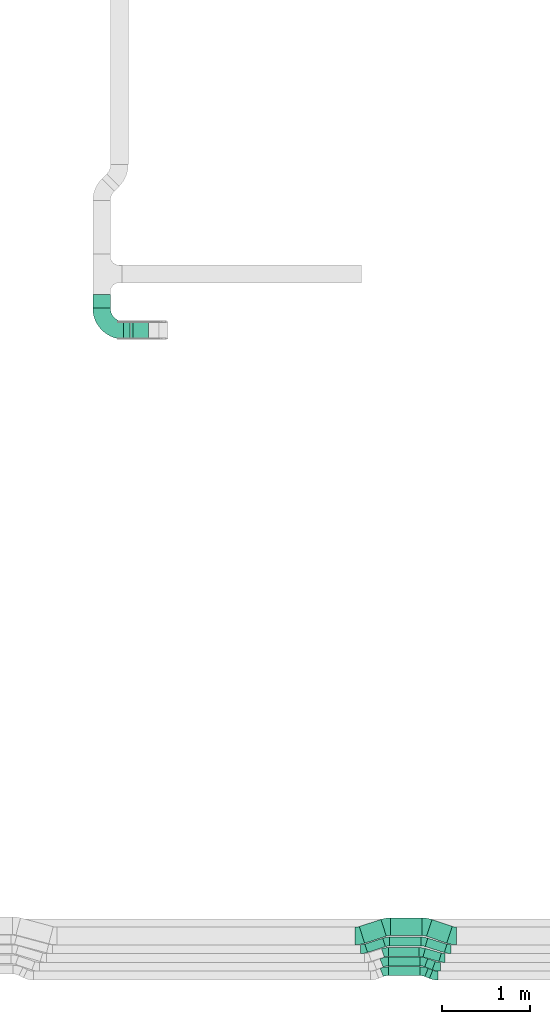
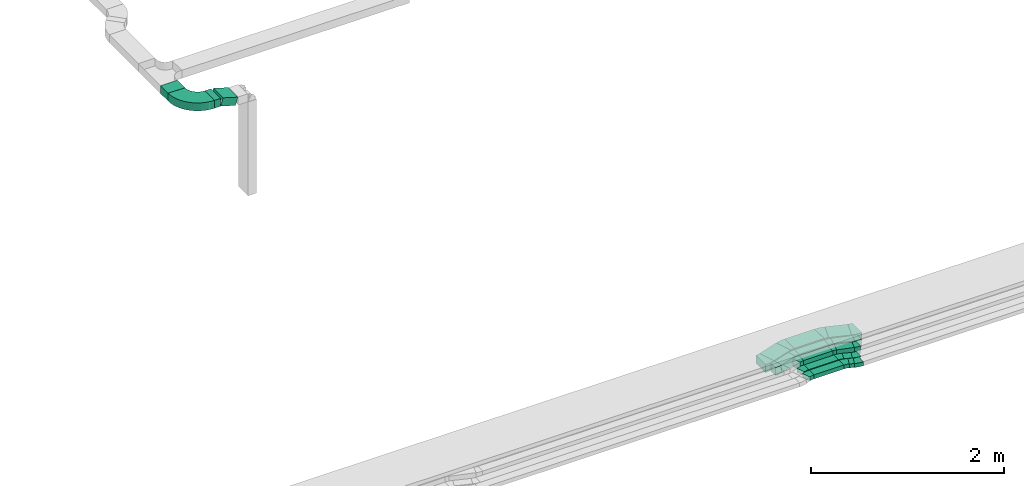
# One storey, part 20 of 38: 18 flow fittings, 15 flow segments.
"""IFC2X3 building model written with IfcOpenShell, lengths in millimetres."""

import ifcopenshell
import ifcopenshell.guid

model = None  # the IFC model being written
_history = None  # IfcOwnerHistory: only IFC2X3 demands one
_inside = {}  # id of a spatial element -> (the spatial element, [elements in it])
_under = {}  # id of a project, library or spatial element -> (it, [spatial elements below it])
_declared = {}  # id of a project -> (the project, [libraries it declares])
_typed = {}  # id of a type object -> (the type object, [elements of that type])
_made_of = {}  # id of a material, layer set ... -> (it, [elements and type objects made of it])


def new_model(schema):
    """Start an empty IFC model of exactly this schema.

    Asked for "IFC4X3", IfcOpenShell would pick the latest addendum, in which some entities
    have other attributes; the version numbers below select the first issue.
    IFC2X3 requires an IfcOwnerHistory on every rooted entity: one is made here for all.
    """
    global model, _history
    if schema == "IFC4X3":
        model = ifcopenshell.file(schema_version=(4, 3, 0, 0))
    else:
        model = ifcopenshell.file(schema=schema)
    _inside.clear()
    _under.clear()
    _declared.clear()
    _typed.clear()
    _made_of.clear()
    _history = None
    if model.schema == "IFC2X3":
        org = make("IfcOrganization", Name="unknown")
        user = make(
            "IfcPersonAndOrganization",
            ThePerson=make("IfcPerson", FamilyName="unknown"),
            TheOrganization=org,
        )
        app = make(
            "IfcApplication",
            ApplicationDeveloper=org,
            Version="unknown",
            ApplicationFullName="unknown",
            ApplicationIdentifier="unknown",
        )
        _history = make(
            "IfcOwnerHistory",
            OwningUser=user,
            OwningApplication=app,
            ChangeAction="ADDED",
            CreationDate=0,
        )
    return model


def make(cls, **values):
    """One entity of the class cls with the attributes given. An attribute that is None is left unset."""
    return model.create_entity(
        cls, **{name: value for name, value in values.items() if value is not None}
    )


def entity(cls, *values):
    """Any entity or typed value of the class cls, its attributes in the order of the schema. None: left unset."""
    e = model.create_entity(cls)
    for i, value in enumerate(values):
        if value is not None:
            e[i] = value
    return e


def rooted(cls, **values):
    """An entity with a GlobalId (a new one), such as an element, a storey or a relation."""
    return make(cls, GlobalId=ifcopenshell.guid.new(), OwnerHistory=_history, **values)


def si_unit(unit_type, name, prefix=None):
    """IfcSIUnit, for example si_unit("LENGTHUNIT", "METRE", prefix="MILLI")."""
    return make("IfcSIUnit", UnitType=unit_type, Prefix=prefix, Name=name)


def converted_unit(unit_type, name, factor, base, dimensions=None, offset=None):
    """IfcConversionBasedUnit, such as the inch: factor (a typed value) times the base unit."""
    return make(
        "IfcConversionBasedUnit"
        if offset is None
        else "IfcConversionBasedUnitWithOffset",
        ConversionOffset=offset,
        Dimensions=None
        if dimensions is None
        else entity("IfcDimensionalExponents", *dimensions),
        UnitType=unit_type,
        Name=name,
        ConversionFactor=make(
            "IfcMeasureWithUnit", ValueComponent=factor, UnitComponent=base
        ),
    )


def derived_unit(unit_type, elements):
    """IfcDerivedUnit: a product of units, each with its exponent."""
    return make(
        "IfcDerivedUnit",
        Elements=[
            make("IfcDerivedUnitElement", Unit=unit, Exponent=power)
            for unit, power in elements
        ],
        UnitType=unit_type,
    )


def assignment(units):
    """IfcUnitAssignment: the units of a project."""
    return None if units is None else make("IfcUnitAssignment", Units=units)


def point(xyz):
    """IfcCartesianPoint."""
    return None if xyz is None else make("IfcCartesianPoint", Coordinates=xyz)


def direction(xyz):
    """IfcDirection."""
    return None if xyz is None else make("IfcDirection", DirectionRatios=xyz)


def frame(location, z_axis=None, x_axis=None):
    """IfcAxis2Placement3D, a coordinate frame: its origin and axes. An axis left out is left unset."""
    return make(
        "IfcAxis2Placement3D",
        Location=point(location),
        Axis=direction(z_axis),
        RefDirection=direction(x_axis),
    )


def frame_2d(location, x_axis=None):
    """IfcAxis2Placement2D, a coordinate frame in the plane: its origin and x axis."""
    return make(
        "IfcAxis2Placement2D", Location=point(location), RefDirection=direction(x_axis)
    )


def origin():
    """The frame at (0, 0, 0) with its axes left unset."""
    return frame((0.0, 0.0, 0.0))


def origin_2d_with_axis():
    """The frame at (0, 0) in the plane with the x axis (1, 0) written out."""
    return frame_2d((0.0, 0.0), x_axis=(1.0, 0.0))


def place(relative_to, where):
    """IfcLocalPlacement: puts the frame where relative to a parent placement (None: the world)."""
    return make(
        "IfcLocalPlacement", PlacementRelTo=relative_to, RelativePlacement=where
    )


def context(
    kind, dimensions, precision=None, world=None, true_north=None, identifier=None
):
    """IfcGeometricRepresentationContext, for example the 3D "Model" context."""
    return make(
        "IfcGeometricRepresentationContext",
        ContextIdentifier=identifier,
        ContextType=kind,
        CoordinateSpaceDimension=dimensions,
        Precision=precision,
        WorldCoordinateSystem=world,
        TrueNorth=true_north,
    )


def subcontext(parent, identifier, kind, view, scale=None):
    """IfcGeometricRepresentationSubContext, for example "Body" below "Model"."""
    return make(
        "IfcGeometricRepresentationSubContext",
        ContextIdentifier=identifier,
        ContextType=kind,
        ParentContext=parent,
        TargetScale=scale,
        TargetView=view,
    )


def project(units=None, contexts=None):
    """IfcProject with its units and contexts."""
    return rooted(
        "IfcProject",
        Name="project",
        RepresentationContexts=contexts,
        UnitsInContext=assignment(units),
    )


def spatial(cls, under=None, at=None, **own):
    """A site, building, storey or space (cls), placed at a placement, below another one or the project."""
    s = rooted(cls, ObjectPlacement=at, **own)
    if under is not None:
        _under.setdefault(under.id(), (under, []))[1].append(s)
    return s


def polyline(points):
    """IfcPolyline through the points."""
    return make("IfcPolyline", Points=[point(p) for p in points])


def circle_curve(where, radius):
    """IfcCircle in the frame where."""
    return make("IfcCircle", Position=where, Radius=radius)


def parameter(value):
    """IfcParameterValue: where a trimmed curve begins or ends, as a parameter of its basis curve."""
    return model.create_entity("IfcParameterValue", value)


def trimmed(basis, trim1, trim2, sense, master):
    """IfcTrimmedCurve: the piece of a basis curve between two trims."""
    return make(
        "IfcTrimmedCurve",
        BasisCurve=basis,
        Trim1=trim1,
        Trim2=trim2,
        SenseAgreement=sense,
        MasterRepresentation=master,
    )


def segment(curve, same_sense, transition):
    """IfcCompositeCurveSegment."""
    return make(
        "IfcCompositeCurveSegment",
        Transition=transition,
        SameSense=same_sense,
        ParentCurve=curve,
    )


def composite_curve(segments, self_intersect=None):
    """IfcCompositeCurve: segments joined end to end."""
    return make("IfcCompositeCurve", Segments=segments, SelfIntersect=self_intersect)


def profile(cls, at=None, kind="AREA", **sizes):
    """A parametric profile (cls). Its sizes go by their IFC names, for example OverallWidth=200.0."""
    return make(cls, ProfileType=kind, Position=at, **sizes)


def rectangle(**sizes):
    """IfcRectangleProfileDef."""
    return profile("IfcRectangleProfileDef", **sizes)


def outline(outer, holes=None, kind="AREA"):
    """IfcArbitraryClosedProfileDef: a profile drawn as a closed curve; with holes, ...WithVoids."""
    if holes is None:
        return make("IfcArbitraryClosedProfileDef", ProfileType=kind, OuterCurve=outer)
    return make(
        "IfcArbitraryProfileDefWithVoids",
        ProfileType=kind,
        OuterCurve=outer,
        InnerCurves=holes,
    )


def extrude(swept, where, along, depth):
    """IfcExtrudedAreaSolid: the profile swept, set in the frame where, extruded along a direction by depth."""
    return make(
        "IfcExtrudedAreaSolid",
        SweptArea=swept,
        Position=where,
        ExtrudedDirection=direction(along),
        Depth=depth,
    )


def shape(context_of_items, identifier, shape_type, items):
    """IfcShapeRepresentation: the items that make up one representation, for example the "Body"."""
    return make(
        "IfcShapeRepresentation",
        ContextOfItems=context_of_items,
        RepresentationIdentifier=identifier,
        RepresentationType=shape_type,
        Items=items,
    )


def source(mapping_origin, context_of_items, identifier, shape_type, items):
    """IfcRepresentationMap: a shape defined once, which mapped items show again and again."""
    return make(
        "IfcRepresentationMap",
        MappingOrigin=mapping_origin,
        MappedRepresentation=shape(context_of_items, identifier, shape_type, items),
    )


def transform(
    local_origin,
    x_axis=None,
    y_axis=None,
    z_axis=None,
    scale=None,
    scale2=None,
    scale3=None,
    uniform=True,
):
    """IfcCartesianTransformationOperator3D, or its non-uniform kind. x_axis, y_axis, z_axis: its Axis1, 2, 3."""
    if uniform:
        return make(
            "IfcCartesianTransformationOperator3D",
            Axis1=direction(x_axis),
            Axis2=direction(y_axis),
            LocalOrigin=point(local_origin),
            Scale=scale,
            Axis3=direction(z_axis),
        )
    return make(
        "IfcCartesianTransformationOperator3DnonUniform",
        Axis1=direction(x_axis),
        Axis2=direction(y_axis),
        LocalOrigin=point(local_origin),
        Scale=scale,
        Axis3=direction(z_axis),
        Scale2=scale2,
        Scale3=scale3,
    )


def mapped(mapping_source, mapping_target):
    """IfcMappedItem: shows the shape of a source again, moved by a transform."""
    return make(
        "IfcMappedItem", MappingSource=mapping_source, MappingTarget=mapping_target
    )


def material(Name=None, Category=None):
    """IfcMaterial."""
    return make("IfcMaterial", Name=Name, Category=Category)


def made_of(thing, what):
    """Note that an element or type object is made of a material, layer set ...; save() writes the relation."""
    if what is not None:
        _made_of.setdefault(what.id(), (what, []))[1].append(thing)
    return thing


def type_object(cls, material=None, **own):
    """A type object (cls), such as IfcWallType, which elements share."""
    return made_of(rooted(cls, **own), material)


def type_shapes(of_type, sources):
    """Give a type object the sources (RepresentationMaps) that its elements show as mapped items."""
    of_type.RepresentationMaps = sources


def element(
    cls,
    number,
    at=None,
    inside=None,
    cuts=None,
    type_object=None,
    material=None,
    context=None,
    identifier="Body",
    shape_type=None,
    held_by="IfcProductDefinitionShape",
    body=None,
    shapes=None,
    **own,
):
    """One element of the class cls, such as IfcWall. Its Tag is "e" and its number.

    at: its placement. inside: the storey or other place that contains it. cuts: it is an
    opening in that element (IfcRelVoidsElement). A single representation is given by context,
    identifier, shape_type and body (its items); several are given by shapes. held_by: the class
    of the entity that holds the representations. save() writes the other relations.
    """
    e = rooted(cls, Tag="e%d" % number, ObjectPlacement=at, **own)
    if body is not None:
        shapes = [shape(context, identifier, shape_type, body)]
    if shapes is not None:
        e.Representation = make(held_by, Representations=shapes)
    if inside is not None:
        _inside.setdefault(inside.id(), (inside, []))[1].append(e)
    if cuts is not None:
        rooted(
            "IfcRelVoidsElement", RelatingBuildingElement=cuts, RelatedOpeningElement=e
        )
    if type_object is not None:
        _typed.setdefault(type_object.id(), (type_object, []))[1].append(e)
    return made_of(e, material)


def aggregate(whole, parts):
    """IfcRelAggregates: a whole, such as a stair, and the parts it consists of."""
    return rooted("IfcRelAggregates", RelatingObject=whole, RelatedObjects=parts)


def save(model, path):
    """Write the relations noted so far, then the file.

    IfcRelAggregates (storeys below a building ...), IfcRelContainedInSpatialStructure (elements
    in a storey), IfcRelDefinesByType, IfcRelAssociatesMaterial and IfcRelDeclares: one each for
    every whole, place, type object, material and project.
    """
    for whole, parts in _under.values():
        aggregate(whole, parts)
    for where, things in _inside.values():
        rooted(
            "IfcRelContainedInSpatialStructure",
            RelatedElements=things,
            RelatingStructure=where,
        )
    for kind, things in _typed.values():
        rooted("IfcRelDefinesByType", RelatedObjects=things, RelatingType=kind)
    for what, things in _made_of.values():
        rooted("IfcRelAssociatesMaterial", RelatedObjects=things, RelatingMaterial=what)
    for by, libraries in _declared.values():
        rooted("IfcRelDeclares", RelatingContext=by, RelatedDefinitions=libraries)
    model.write(path)


model = new_model("IFC2X3")

# Units and contexts
model_context = context("Model", 3, precision=0.01, world=origin(), true_north=direction((6.12303176911189e-17, 1.0)))
body_context = subcontext(model_context, "Body", "Model", "MODEL_VIEW")
ifc_project = project(units=[si_unit("LENGTHUNIT", "METRE", prefix="MILLI"), si_unit("AREAUNIT", "SQUARE_METRE"), si_unit("VOLUMEUNIT", "CUBIC_METRE"), converted_unit("PLANEANGLEUNIT", "DEGREE", entity("IfcRatioMeasure", 0.0174532925199433), si_unit("PLANEANGLEUNIT", "RADIAN"), dimensions=[0, 0, 0, 0, 0, 0, 0]), si_unit("MASSUNIT", "GRAM", prefix="KILO"), derived_unit("MASSDENSITYUNIT", [(si_unit("MASSUNIT", "GRAM", prefix="KILO"), 1), (si_unit("LENGTHUNIT", "METRE"), -3)]), derived_unit("MOMENTOFINERTIAUNIT", [(si_unit("LENGTHUNIT", "METRE"), 4)]), si_unit("TIMEUNIT", "SECOND"), si_unit("FREQUENCYUNIT", "HERTZ"), si_unit("THERMODYNAMICTEMPERATUREUNIT", "DEGREE_CELSIUS"), derived_unit("THERMALTRANSMITTANCEUNIT", [(si_unit("MASSUNIT", "GRAM", prefix="KILO"), 1), (si_unit("THERMODYNAMICTEMPERATUREUNIT", "KELVIN"), -1), (si_unit("TIMEUNIT", "SECOND"), -3)]), derived_unit("VOLUMETRICFLOWRATEUNIT", [(si_unit("LENGTHUNIT", "METRE"), 3), (si_unit("TIMEUNIT", "SECOND"), -1)]), derived_unit("MASSFLOWRATEUNIT", [(si_unit("MASSUNIT", "GRAM", prefix="KILO"), 1), (si_unit("TIMEUNIT", "SECOND"), -1)]), derived_unit("ROTATIONALFREQUENCYUNIT", [(si_unit("TIMEUNIT", "SECOND"), -1)]), si_unit("ELECTRICCURRENTUNIT", "AMPERE"), si_unit("ELECTRICVOLTAGEUNIT", "VOLT"), si_unit("POWERUNIT", "WATT"), si_unit("FORCEUNIT", "NEWTON", prefix="KILO"), si_unit("ILLUMINANCEUNIT", "LUX"), si_unit("LUMINOUSFLUXUNIT", "LUMEN"), si_unit("LUMINOUSINTENSITYUNIT", "CANDELA"), derived_unit("USERDEFINED", [(si_unit("MASSUNIT", "GRAM", prefix="KILO"), -1), (si_unit("LENGTHUNIT", "METRE"), -2), (si_unit("TIMEUNIT", "SECOND"), 3), (si_unit("LUMINOUSFLUXUNIT", "LUMEN"), 1)]), derived_unit("LINEARVELOCITYUNIT", [(si_unit("LENGTHUNIT", "METRE"), 1), (si_unit("TIMEUNIT", "SECOND"), -1)]), si_unit("PRESSUREUNIT", "PASCAL"), derived_unit("USERDEFINED", [(si_unit("LENGTHUNIT", "METRE"), -2), (si_unit("MASSUNIT", "GRAM", prefix="KILO"), 1), (si_unit("TIMEUNIT", "SECOND"), -2)]), derived_unit("LINEARFORCEUNIT", [(si_unit("MASSUNIT", "GRAM", prefix="KILO"), 1), (si_unit("LENGTHUNIT", "METRE"), 1), (si_unit("TIMEUNIT", "SECOND"), -2), (si_unit("LENGTHUNIT", "METRE"), -1)]), derived_unit("PLANARFORCEUNIT", [(si_unit("MASSUNIT", "GRAM", prefix="KILO"), 1), (si_unit("LENGTHUNIT", "METRE"), 1), (si_unit("TIMEUNIT", "SECOND"), -2), (si_unit("LENGTHUNIT", "METRE"), -2)])], contexts=[model_context])

# Site, building, storey
site_placement = place(None, frame((0.0, -0.00077364408347762, 0.0)))
site = spatial("IfcSite", under=ifc_project, at=site_placement, CompositionType="ELEMENT")
building_placement = place(site_placement, origin())
building = spatial("IfcBuilding", under=site, at=building_placement, CompositionType="ELEMENT")
storey_placement = place(building_placement, frame((0.0, 0.0, 4200.0)))
storey = spatial("IfcBuildingStorey", under=building, at=storey_placement, CompositionType="ELEMENT", Elevation=4200.0)

# Flow segments
cable_carrier_segment_type = type_object("IfcCableCarrierSegmentType", PredefinedType="CABLETRAYSEGMENT")
flow_segment_1_placement = place(storey_placement, frame((30289.3681422249, 297.228892383156, 2836.0)))
element("IfcFlowSegment", 1, at=flow_segment_1_placement, inside=storey, type_object=cable_carrier_segment_type, context=body_context, shape_type="SweptSolid", body=[
    extrude(rectangle(XDim=355.247876344916, YDim=100.0, at=frame_2d((2.1600499167107e-12, 3.19744231092045e-14), x_axis=(1.0, 0.0))), frame((177.623938172456, 50.0, 0.0)), (0.0, 0.0, 1.0), 49.9999999999995),
])
flow_segment_2_placement = place(storey_placement, frame((30702.7341914367, 265.23564522372, 2836.0)))
element("IfcFlowSegment", 2, at=flow_segment_2_placement, inside=storey, type_object=cable_carrier_segment_type, context=body_context, shape_type="SweptSolid", body=[
    extrude(rectangle(XDim=55.2478763449133, YDim=100.0, at=frame_2d((2.00905958536168e-12, 8.10018718766514e-13), x_axis=(1.0, 0.0))), frame((44.3427991438556, 56.7073021038568, 0.0), z_axis=(0.0, 0.0, 1.0), x_axis=(0.927183854566696, -0.374606593416139, 0.0)), (0.0, 0.0, 1.0), 49.9999999999995),
])
flow_segment_3_placement = place(storey_placement, frame((30287.547738589, 406.594057218529, 2836.0)))
element("IfcFlowSegment", 3, at=flow_segment_3_placement, inside=storey, type_object=cable_carrier_segment_type, context=body_context, shape_type="SweptSolid", body=[
    extrude(rectangle(XDim=357.168656212116, YDim=100.0, at=frame_2d((0.0, -3.19744231092045e-14), x_axis=(1.0, 0.0))), frame((178.584328106058, 50.0, 0.0)), (0.0, 0.0, 1.0), 49.9999999999995),
])
flow_segment_4_placement = place(storey_placement, frame((30700.2531635223, 363.521908837106, 2836.0)))
element("IfcFlowSegment", 4, at=flow_segment_4_placement, inside=storey, type_object=cable_carrier_segment_type, context=body_context, shape_type="SweptSolid", body=[
    extrude(rectangle(XDim=91.8149731757522, YDim=99.9999999999983, at=frame_2d((-2.03570493795269e-12, -7.38964445190504e-13), x_axis=(1.0, 0.0))), frame((60.7438048738638, 63.103620908118, 0.0), z_axis=(0.0, 0.0, 1.0), x_axis=(-0.933969781710923, 0.357351992929731, 0.0)), (0.0, 0.0, 1.0), 49.9999999999995),
])
flow_segment_5_placement = place(storey_placement, frame((30288.9478204712, 514.64074103447, 2836.0)))
element("IfcFlowSegment", 5, at=flow_segment_5_placement, inside=storey, type_object=cable_carrier_segment_type, context=body_context, shape_type="SweptSolid", body=[
    extrude(rectangle(XDim=348.21494499462, YDim=99.9999999999999, at=frame_2d((2.1600499167107e-12, 3.19744231092045e-14), x_axis=(1.0, 0.0))), frame((174.107472497308, 50.0, 0.0)), (0.0, 0.0, 1.0), 99.9999999999989),
])
flow_segment_6_placement = place(storey_placement, frame((30680.4696305343, 456.617215643215, 2836.0)))
element("IfcFlowSegment", 6, at=flow_segment_6_placement, inside=storey, type_object=cable_carrier_segment_type, context=body_context, shape_type="SweptSolid", body=[
    extrude(rectangle(XDim=188.425630017471, YDim=100.000000000002, at=frame_2d((2.08189021577709e-12, 5.96855898038484e-13), x_axis=(1.0, 0.0))), frame((104.345038125269, 74.0316560100125, 0.0), z_axis=(0.0, 0.0, 1.0), x_axis=(0.961261695938276, -0.275637355817147, 0.0)), (0.0, 0.0, 1.0), 100.000000000001),
])
flow_segment_7_placement = place(storey_placement, frame((30020.1489786803, 559.201890192596, 2836.0)))
element("IfcFlowSegment", 7, at=flow_segment_7_placement, inside=storey, type_object=cable_carrier_segment_type, context=body_context, shape_type="SweptSolid", body=[
    extrude(rectangle(XDim=214.646223870171, YDim=99.9999999999981, at=frame_2d((7.105427357601e-15, 3.5527136788005e-14), x_axis=(1.0, 0.0))), frame((117.521194673687, 80.7174912919277, 0.0), z_axis=(0.0, 0.0, 1.0), x_axis=(0.951056516295066, 0.309016994375216, 0.0)), (0.0, 0.0, 1.0), 99.9999999999989),
])
flow_segment_8_placement = place(storey_placement, frame((30303.4949737002, 633.181760697043, 2836.0)))
element("IfcFlowSegment", 8, at=flow_segment_8_placement, inside=storey, type_object=cable_carrier_segment_type, context=body_context, shape_type="SweptSolid", body=[
    extrude(rectangle(XDim=355.881223412283, YDim=100.0, at=origin_2d_with_axis()), frame((177.940611706142, 50.0, 0.0)), (0.0, 0.0, 1.0), 99.9999999999989),
])
flow_segment_9_placement = place(storey_placement, frame((30705.9597944176, 558.276090646395, 2836.0)))
element("IfcFlowSegment", 9, at=flow_segment_9_placement, inside=storey, type_object=cable_carrier_segment_type, context=body_context, shape_type="SweptSolid", body=[
    extrude(rectangle(XDim=227.930438544839, YDim=100.000000000001, at=frame_2d((2.06767936106189e-12, 6.43041175862891e-13), x_axis=(1.0, 0.0))), frame((123.680456386799, 81.6432908381334, 0.0), z_axis=(0.0, 0.0, 1.0), x_axis=(-0.954713750063921, 0.297525890367351, 0.0)), (0.0, 0.0, 1.0), 99.9999999999989),
])
flow_segment_10_placement = place(storey_placement, frame((29957.093992222, 664.096238563172, 2836.0)))
element("IfcFlowSegment", 10, at=flow_segment_10_placement, inside=storey, type_object=cable_carrier_segment_type, context=body_context, shape_type="SweptSolid", body=[
    extrude(rectangle(XDim=258.80777983768, YDim=199.999999999997, at=frame_2d((-1.4210854715202e-14, -7.105427357601e-14), x_axis=(1.0, 0.0))), frame((153.972112178759, 135.093652752682, 0.0), z_axis=(0.0, 0.0, 1.0), x_axis=(0.951056516295083, 0.309016994375165, 0.0)), (0.0, 0.0, 1.0), 99.9999999999989),
])
flow_segment_11_placement = place(storey_placement, frame((30313.3418222521, 751.722780359626, 2836.0)))
element("IfcFlowSegment", 11, at=flow_segment_11_placement, inside=storey, type_object=cable_carrier_segment_type, context=body_context, shape_type="SweptSolid", body=[
    extrude(rectangle(XDim=357.073435483286, YDim=200.0, at=frame_2d((0.0, 6.3948846218409e-14), x_axis=(1.0, 0.0))), frame((178.536717741643, 100.0, 0.0)), (0.0, 0.0, 1.0), 99.9999999999989),
])
flow_segment_12_placement = place(storey_placement, frame((30720.6391194544, 665.601773024996, 2836.0)))
element("IfcFlowSegment", 12, at=flow_segment_12_placement, inside=storey, type_object=cable_carrier_segment_type, context=body_context, shape_type="SweptSolid", body=[
    extrude(rectangle(XDim=241.785304404678, YDim=199.999999999999, at=frame_2d((-4.2632564145606e-14, 1.27897692436818e-13), x_axis=(1.0, 0.0))), frame((146.644866646475, 133.588118290864, 0.0), z_axis=(0.0, 0.0, 1.0), x_axis=(0.946791646802566, -0.32184713381493, 0.0)), (0.0, 0.0, 1.0), 99.9999999999989),
])
flow_segment_13_placement = place(storey_placement, frame((26931.2155509647, 7876.00077377345, 2930.0)))
element("IfcFlowSegment", 13, at=flow_segment_13_placement, inside=storey, type_object=cable_carrier_segment_type, context=body_context, shape_type="SweptSolid", body=[
    extrude(rectangle(XDim=157.794446137096, YDim=199.999999999998, at=origin_2d_with_axis()), frame((100.0, 78.897223068548, 0.0), z_axis=(0.0, 0.0, 1.0), x_axis=(0.0, -1.0, 0.0)), (0.0, 0.0, 1.0), 99.9999999999989),
])
flow_segment_14_placement = place(storey_placement, frame((27282.2155509647, 7525.00077377345, 2930.0)))
element("IfcFlowSegment", 14, at=flow_segment_14_placement, inside=storey, type_object=cable_carrier_segment_type, context=body_context, shape_type="SweptSolid", body=[
    extrude(rectangle(XDim=72.5981362429797, YDim=200.0, at=frame_2d((-2.16715534406831e-12, 0.0), x_axis=(1.0, 0.0))), frame((36.2990681215397, 100.0, 0.0)), (0.0, 0.0, 1.0), 100.000000000002),
])
flow_segment_15_placement = place(storey_placement, frame((27357.9178648471, 7525.00077377346, 2876.60803547914)))
element("IfcFlowSegment", 15, at=flow_segment_15_placement, inside=storey, type_object=cable_carrier_segment_type, context=body_context, shape_type="SweptSolid", body=[
    extrude(rectangle(XDim=100.000000000003, YDim=184.756947560812, at=frame_2d((0.0, 0.0), x_axis=(0.0, 1.0))), frame((102.83157932693, 0.0, 74.3724824400349), z_axis=(0.0, 1.0, 0.0), x_axis=(0.958072371885015, 0.0, -0.286526316820327)), (0.0, 0.0, 1.0), 200.0),
])

# Flow fittings
ifc_material = material()
cable_carrier_fitting_type_1 = type_object("IfcCableCarrierFittingType", Name="470_DKC_S5_Variable Angle Elbow 0-45:-", PredefinedType="NOTDEFINED", material=ifc_material)
shared_shape_1 = source(origin(), body_context, "Body", "SweptSolid", [
    extrude(outline(composite_curve([segment(polyline([(-125.750000000001, -225.25), (-124.749999999999, -225.25)]), True, "CONTINUOUS"), segment(trimmed(circle_curve(frame_2d((-124.75, 124.75), x_axis=(0.0, -1.0)), 350.0), [parameter(0.0)], [parameter(90.0000000000001)], True, "PARAMETER"), True, "CONTINUOUS"), segment(polyline([(225.25, 124.75), (225.25, 125.749999999999)]), True, "CONTINUOUS"), segment(polyline([(225.25, 125.749999999999), (25.25, 125.750000000001)]), True, "CONTINUOUS"), segment(polyline([(25.25, 125.750000000001), (25.25, 124.75)]), True, "CONTINUOUS"), segment(trimmed(circle_curve(frame_2d((-124.75, 124.75), x_axis=(0.0, -1.0)), 150.0), [parameter(0.0)], [parameter(90.0000000000001)], True, "PARAMETER"), False, "CONTINUOUS"), segment(polyline([(-124.749999999999, -25.2500000000003), (-125.750000000001, -25.2500000000003)]), True, "CONTINUOUS"), segment(polyline([(-125.750000000001, -25.2500000000003), (-125.750000000001, -225.25)]), True, "CONTINUOUS")], self_intersect=False)), frame((-125.249999999991, 125.249999999992, -50.0)), (0.0, 0.0, 1.0), 100.0),
])
type_shapes(cable_carrier_fitting_type_1, [shared_shape_1])
flow_fitting_1_placement = place(storey_placement, frame((27031.2155509647, 7625.00077377346, 2980.0), z_axis=(0.0, 0.0, 1.0), x_axis=(0.0, -1.0, 0.0)))
element("IfcFlowFitting", 16, at=flow_fitting_1_placement, inside=storey, type_object=cable_carrier_fitting_type_1, material=ifc_material, Name="470_DKC_S5_Variable Angle Elbow 0-45:-", ObjectType="470_DKC_S5_Variable Angle Elbow 0-45:-", context=body_context, shape_type="MappedRepresentation", body=[
    mapped(shared_shape_1, transform((0.0, 0.0, 0.0), scale=1.0)),
])
cable_carrier_fitting_type_2 = type_object("IfcCableCarrierFittingType", Name="470_DKC_S5_Variable Angle Elbow 0-45:-", PredefinedType="NOTDEFINED", material=ifc_material)
shared_shape_2 = source(origin(), body_context, "Body", "SweptSolid", [
    extrude(outline(composite_curve([segment(polyline([(-38.442455305234, -57.3752661916753), (-37.4424553052327, -57.3752661916753)]), True, "CONTINUOUS"), segment(trimmed(circle_curve(frame_2d((-37.4424553052331, 192.624733808324), x_axis=(0.0, -1.0)), 250.0), [parameter(0.0)], [parameter(22.0)], True, "PARAMETER"), True, "CONTINUOUS"), segment(polyline([(56.2091930487454, -39.1712298333719), (57.1363769033121, -38.7966232399561)]), True, "CONTINUOUS"), segment(polyline([(57.1363769033121, -38.7966232399561), (19.6757175617208, 53.9217622167225)]), True, "CONTINUOUS"), segment(polyline([(19.6757175617208, 53.9217622167225), (18.748533707154, 53.5471556233066)]), True, "CONTINUOUS"), segment(trimmed(circle_curve(frame_2d((-37.4424553052331, 192.624733808324), x_axis=(0.0, -1.0)), 150.0), [parameter(0.0)], [parameter(22.0)], True, "PARAMETER"), False, "CONTINUOUS"), segment(polyline([(-37.4424553052327, 42.6247338083246), (-38.442455305234, 42.6247338083246)]), True, "CONTINUOUS"), segment(polyline([(-38.442455305234, 42.6247338083246), (-38.442455305234, -57.3752661916753)]), True, "CONTINUOUS")], self_intersect=False)), frame((-1.43360652230106, 7.37526619166724, -25.0)), (0.0, 0.0, 1.0), 50.0000000000001),
])
type_shapes(cable_carrier_fitting_type_2, [shared_shape_2])
for number, where, z_axis, x_axis, name in (
    (17, (30249.4920803973, 347.228892383139, 2861.0), (0.0, 0.0, 1.0), (-1.0, 0.0, 0.0), "470_DKC_S5_Variable Angle Elbow 0-45:-"),
    (18, (30684.4920803973, 347.228892383136, 2861.0), (0.0, 0.0, 1.0), (-0.927183854566786, 0.374606593415915, 0.0), "470_DKC_S5_Variable Angle Elbow 0-45:-"),
    (19, (30809.6619007638, 296.657002271998, 2861.0), (0.0, 0.0, 1.0), (0.927183854566699, -0.374606593416131, 0.0), "470_DKC_S5_Variable Angle Elbow 0-45:-"),
    (20, (30247.6716767615, 456.594057218512, 2861.0), (0.0, 0.0, 1.0), (-1.0, 0.0, 0.0), "470_DKC_S5_Variable Angle Elbow 0-45:-"),
):
    element("IfcFlowFitting", number, at=place(storey_placement, frame(where, z_axis=z_axis, x_axis=x_axis)), inside=storey, type_object=cable_carrier_fitting_type_2, material=ifc_material, Name=name, ObjectType="470_DKC_S5_Variable Angle Elbow 0-45:-", context=body_context, shape_type="MappedRepresentation", body=[
        mapped(shared_shape_2, transform((0.0, 0.0, 0.0), scale=1.0)),
    ])
cable_carrier_fitting_type_3 = type_object("IfcCableCarrierFittingType", Name="470_DKC_S5_Variable Angle Elbow 0-45:-", PredefinedType="NOTDEFINED", material=ifc_material)
shared_shape_3 = source(origin(), body_context, "Body", "SweptSolid", [
    extrude(outline(composite_curve([segment(polyline([(-36.7186917383869, -56.6923598271344), (-35.7186917383856, -56.6923598271344)]), True, "CONTINUOUS"), segment(trimmed(circle_curve(frame_2d((-35.718691738386, 193.307640172865), x_axis=(0.0, -1.0)), 250.0), [parameter(0.0)], [parameter(20.9376616272473)], True, "PARAMETER"), True, "CONTINUOUS"), segment(polyline([(53.6193064940096, -40.1848052548794), (54.5532762757203, -39.8274532619499)]), True, "CONTINUOUS"), segment(polyline([(54.5532762757203, -39.8274532619499), (18.8180769827625, 53.5695249091482)]), True, "CONTINUOUS"), segment(polyline([(18.8180769827626, 53.5695249091482), (17.8841072010513, 53.2121729162185)]), True, "CONTINUOUS"), segment(trimmed(circle_curve(frame_2d((-35.718691738386, 193.307640172865), x_axis=(0.0, -1.0)), 150.0), [parameter(0.0)], [parameter(20.9376616272473)], True, "PARAMETER"), False, "CONTINUOUS"), segment(polyline([(-35.7186917383856, 43.3076401728655), (-36.7186917383869, 43.3076401728655)]), True, "CONTINUOUS"), segment(polyline([(-36.7186917383869, 43.3076401728655), (-36.7186917383869, -56.6923598271344)]), True, "CONTINUOUS")], self_intersect=False)), frame((-1.23659022194941, 6.69235982712632, -25.0)), (0.0, 0.0, 1.0), 50.0000000000001),
])
type_shapes(cable_carrier_fitting_type_3, [shared_shape_3])
for number, where, z_axis, x_axis, name in (
    (21, (30839.3222600308, 396.657002271936, 2861.0), (0.0, 0.0, 1.0), (0.933969781710955, -0.357351992929648, 0.0), "470_DKC_S5_Variable Angle Elbow 0-45:-"),
    (22, (30682.6716767615, 456.59405721852, 2861.0), (0.0, 0.0, 1.0), (-0.933969781710923, 0.357351992929732, 0.0), "470_DKC_S5_Variable Angle Elbow 0-45:-"),
):
    element("IfcFlowFitting", number, at=place(storey_placement, frame(where, z_axis=z_axis, x_axis=x_axis)), inside=storey, type_object=cable_carrier_fitting_type_3, material=ifc_material, Name=name, ObjectType="470_DKC_S5_Variable Angle Elbow 0-45:-", context=body_context, shape_type="MappedRepresentation", body=[
        mapped(shared_shape_3, transform((0.0, 0.0, 0.0), scale=1.0)),
    ])
cable_carrier_fitting_type_4 = type_object("IfcCableCarrierFittingType", Name="470_DKC_S5_Variable Angle Elbow 0-45:-", PredefinedType="NOTDEFINED", material=ifc_material)
shared_shape_4 = source(origin(), body_context, "Body", "SweptSolid", [
    extrude(outline(composite_curve([segment(polyline([(-31.8894635665691, -54.9716026190787), (-30.8894635665678, -54.9716026190787)]), True, "CONTINUOUS"), segment(trimmed(circle_curve(frame_2d((-30.8894635665704, 195.028397380921), x_axis=(0.0, -1.0)), 250.0), [parameter(0.0)], [parameter(18.0)], True, "PARAMETER"), True, "CONTINUOUS"), segment(polyline([(46.3647850271689, -42.7357316928663), (47.315841543464, -42.4267146984913)]), True, "CONTINUOUS"), segment(polyline([(47.315841543464, -42.4267146984913), (16.4141421059684, 52.6789369310236)]), True, "CONTINUOUS"), segment(polyline([(16.4141421059684, 52.6789369310236), (15.4630855896732, 52.3699199366487)]), True, "CONTINUOUS"), segment(trimmed(circle_curve(frame_2d((-30.8894635665704, 195.028397380921), x_axis=(0.0, -1.0)), 150.0), [parameter(0.0)], [parameter(18.0)], True, "PARAMETER"), False, "CONTINUOUS"), segment(polyline([(-30.8894635665686, 45.0283973809212), (-31.88946356657, 45.0283973809212)]), True, "CONTINUOUS"), segment(polyline([(-31.88946356657, 45.0283973809212), (-31.8894635665691, -54.9716026190787)]), True, "CONTINUOUS")], self_intersect=False)), frame((-0.787424498328968, 4.97160261907036, -50.0)), (0.0, 0.0, 1.0), 100.0),
])
type_shapes(cable_carrier_fitting_type_4, [shared_shape_4])
flow_fitting_2_placement = place(storey_placement, frame((30256.2709324063, 564.640741034454, 2886.0), z_axis=(0.0, 0.0, 1.0), x_axis=(-1.0, 0.0, 0.0)))
element("IfcFlowFitting", 23, at=flow_fitting_2_placement, inside=storey, type_object=cable_carrier_fitting_type_4, material=ifc_material, Name="470_DKC_S5_Variable Angle Elbow 0-45:-", ObjectType="470_DKC_S5_Variable Angle Elbow 0-45:-", context=body_context, shape_type="MappedRepresentation", body=[
    mapped(shared_shape_4, transform((0.0, 0.0, 0.0), scale=1.0)),
])
flow_fitting_3_placement = place(storey_placement, frame((30004.5222610726, 596.657002272021, 2886.0)))
element("IfcFlowFitting", 24, at=flow_fitting_3_placement, inside=storey, type_object=cable_carrier_fitting_type_4, material=ifc_material, Name="470_DKC_S5_Variable Angle Elbow 0-45:-", ObjectType="470_DKC_S5_Variable Angle Elbow 0-45:-", context=body_context, shape_type="MappedRepresentation", body=[
    mapped(shared_shape_4, transform((0.0, 0.0, 0.0), scale=1.0)),
])
flow_fitting_4_placement = place(storey_placement, frame((30270.8180856353, 683.181760697027, 2886.0), z_axis=(0.0, 0.0, 1.0), x_axis=(-1.0, 0.0, 0.0)))
element("IfcFlowFitting", 25, at=flow_fitting_4_placement, inside=storey, type_object=cable_carrier_fitting_type_4, material=ifc_material, Name="470_DKC_S5_Variable Angle Elbow 0-45:-", ObjectType="470_DKC_S5_Variable Angle Elbow 0-45:-", context=body_context, shape_type="MappedRepresentation", body=[
    mapped(shared_shape_4, transform((0.0, 0.0, 0.0), scale=1.0)),
])
cable_carrier_fitting_type_5 = type_object("IfcCableCarrierFittingType", Name="470_DKC_S5_Variable Angle Elbow 0-45:-", PredefinedType="NOTDEFINED", material=ifc_material)
shared_shape_5 = source(origin(), body_context, "Body", "SweptSolid", [
    extrude(outline(composite_curve([segment(polyline([(-28.5540510056852, -53.9427397451227), (-27.5540510056839, -53.9427397451227)]), True, "CONTINUOUS"), segment(trimmed(circle_curve(frame_2d((-27.5540510056865, 196.057260254877), x_axis=(0.0, -1.0)), 250.0), [parameter(0.0)], [parameter(16.0000000000001)], True, "PARAMETER"), True, "CONTINUOUS"), segment(polyline([(41.3552879485661, -44.2581637297016), (42.3165496445045, -43.9825263738845)]), True, "CONTINUOUS"), segment(polyline([(42.3165496445045, -43.9825263738846), (14.7528140628032, 52.1436432199469)]), True, "CONTINUOUS"), segment(polyline([(14.7528140628032, 52.1436432199469), (13.791552366865, 51.8680058641299)]), True, "CONTINUOUS"), segment(trimmed(circle_curve(frame_2d((-27.5540510056865, 196.057260254877), x_axis=(0.0, -1.0)), 150.0), [parameter(0.0)], [parameter(16.0000000000001)], True, "PARAMETER"), False, "CONTINUOUS"), segment(polyline([(-27.5540510056847, 46.0572602548772), (-28.5540510056861, 46.0572602548772)]), True, "CONTINUOUS"), segment(polyline([(-28.5540510056861, 46.0572602548772), (-28.5540510056852, -53.9427397451227)]), True, "CONTINUOUS")], self_intersect=False)), frame((-0.554115934784018, 3.94273974511436, -50.0)), (0.0, 0.0, 1.0), 100.0),
])
type_shapes(cable_carrier_fitting_type_5, [shared_shape_5])
for number, where, z_axis, x_axis, name in (
    (26, (30666.2709324063, 564.640741034462, 2886.0), (0.0, 0.0, 1.0), (-0.96126169593829, 0.2756373558171, 0.0), "470_DKC_S5_Variable Angle Elbow 0-45:-"),
    (27, (30903.3584049129, 496.657002271983, 2886.0), (0.0, 0.0, 1.0), (0.961261695938276, -0.275637355817149, 0.0), "470_DKC_S5_Variable Angle Elbow 0-45:-"),
):
    element("IfcFlowFitting", number, at=place(storey_placement, frame(where, z_axis=z_axis, x_axis=x_axis)), inside=storey, type_object=cable_carrier_fitting_type_5, material=ifc_material, Name=name, ObjectType="470_DKC_S5_Variable Angle Elbow 0-45:-", context=body_context, shape_type="MappedRepresentation", body=[
        mapped(shared_shape_5, transform((0.0, 0.0, 0.0), scale=1.0)),
    ])
cable_carrier_fitting_type_6 = type_object("IfcCableCarrierFittingType", Name="470_DKC_S5_Variable Angle Elbow 0-45:-", PredefinedType="NOTDEFINED", material=ifc_material)
shared_shape_6 = source(origin(), body_context, "Body", "SweptSolid", [
    extrude(outline(composite_curve([segment(polyline([(-30.7412674742448, -54.6030064661979), (-29.7412674742435, -54.6030064661979)]), True, "CONTINUOUS"), segment(trimmed(circle_curve(frame_2d((-29.741267474246, 195.396993533802), x_axis=(0.0, -1.0)), 250.0), [parameter(0.0)], [parameter(17.3090628031778)], True, "PARAMETER"), True, "CONTINUOUS"), segment(polyline([(44.6402051175769, -43.2814439821827), (45.5949188676407, -42.9839180918155)]), True, "CONTINUOUS"), segment(polyline([(45.5949188676407, -42.9839180918155), (15.8423298309118, 52.4874569145784)]), True, "CONTINUOUS"), segment(polyline([(15.8423298309118, 52.4874569145785), (14.8876160808477, 52.1899310242111)]), True, "CONTINUOUS"), segment(trimmed(circle_curve(frame_2d((-29.741267474246, 195.396993533802), x_axis=(0.0, -1.0)), 150.0), [parameter(0.0)], [parameter(17.3090628031778)], True, "PARAMETER"), False, "CONTINUOUS"), segment(polyline([(-29.7412674742443, 45.396993533802), (-30.7412674742456, 45.396993533802)]), True, "CONTINUOUS"), segment(polyline([(-30.7412674742456, 45.396993533802), (-30.7412674742448, -54.6030064661979)]), True, "CONTINUOUS")], self_intersect=False)), frame((-0.700621048559091, 4.60300646618954, -50.0)), (0.0, 0.0, 1.0), 100.0),
])
type_shapes(cable_carrier_fitting_type_6, [shared_shape_6])
for number, where, z_axis, x_axis, name in (
    (28, (30968.4624159735, 596.657002272032, 2886.0), (0.0, 0.0, 1.0), (0.954713750063932, -0.297525890367316, 0.0), "470_DKC_S5_Variable Angle Elbow 0-45:-"),
    (29, (30690.8180856353, 683.181760697034, 2886.0), (0.0, 0.0, 1.0), (-0.954713750063921, 0.297525890367352, 0.0), "470_DKC_S5_Variable Angle Elbow 0-45:-"),
):
    element("IfcFlowFitting", number, at=place(storey_placement, frame(where, z_axis=z_axis, x_axis=x_axis)), inside=storey, type_object=cable_carrier_fitting_type_6, material=ifc_material, Name=name, ObjectType="470_DKC_S5_Variable Angle Elbow 0-45:-", context=body_context, shape_type="MappedRepresentation", body=[
        mapped(shared_shape_6, transform((0.0, 0.0, 0.0), scale=1.0)),
    ])
cable_carrier_fitting_type_7 = type_object("IfcCableCarrierFittingType", Name="470_DKC_S5_Variable Angle Elbow 0-45:-", PredefinedType="NOTDEFINED", material=ifc_material)
shared_shape_7 = source(origin(), body_context, "Body", "SweptSolid", [
    extrude(outline(composite_curve([segment(polyline([(-39.6148884259598, -106.195189711705), (-38.6148884259583, -106.195189711705)]), True, "CONTINUOUS"), segment(trimmed(circle_curve(frame_2d((-38.6148884259589, 243.804810288295), x_axis=(0.0, -1.0)), 350.0), [parameter(0.0)], [parameter(18.0000000000079)], True, "PARAMETER"), True, "CONTINUOUS"), segment(polyline([(69.5410596053193, -89.0649704149935), (70.4921161216141, -88.7559534206186)]), True, "CONTINUOUS"), segment(polyline([(70.4921161216141, -88.7559534206186), (8.68871724659853, 101.455349838404)]), True, "CONTINUOUS"), segment(polyline([(8.68871724659851, 101.455349838404), (7.73766073030314, 101.146332844028)]), True, "CONTINUOUS"), segment(trimmed(circle_curve(frame_2d((-38.6148884259589, 243.804810288295), x_axis=(0.0, -1.0)), 150.0), [parameter(0.0)], [parameter(18.0000000000079)], True, "PARAMETER"), False, "CONTINUOUS"), segment(polyline([(-38.6148884259583, 93.8048102882949), (-39.6148884259598, 93.8048102882949)]), True, "CONTINUOUS"), segment(polyline([(-39.6148884259598, 93.8048102882949), (-39.6148884259598, -106.195189711705)]), True, "CONTINUOUS")], self_intersect=False)), frame((-0.981221655183294, 6.1951897116969, -50.0)), (0.0, 0.0, 1.0), 100.0),
])
type_shapes(cable_carrier_fitting_type_7, [shared_shape_7])
flow_fitting_5_placement = place(storey_placement, frame((29949.3864966306, 746.657002272098, 2886.0)))
element("IfcFlowFitting", 30, at=flow_fitting_5_placement, inside=storey, type_object=cable_carrier_fitting_type_7, material=ifc_material, Name="470_DKC_S5_Variable Angle Elbow 0-45:-", ObjectType="470_DKC_S5_Variable Angle Elbow 0-45:-", context=body_context, shape_type="MappedRepresentation", body=[
    mapped(shared_shape_7, transform((0.0, 0.0, 0.0), scale=1.0)),
])
flow_fitting_6_placement = place(storey_placement, frame((30272.7457121709, 851.722780359609, 2886.0), z_axis=(0.0, 0.0, 1.0), x_axis=(-1.0, 0.0, 0.0)))
element("IfcFlowFitting", 31, at=flow_fitting_6_placement, inside=storey, type_object=cable_carrier_fitting_type_7, material=ifc_material, Name="470_DKC_S5_Variable Angle Elbow 0-45:-", ObjectType="470_DKC_S5_Variable Angle Elbow 0-45:-", context=body_context, shape_type="MappedRepresentation", body=[
    mapped(shared_shape_7, transform((0.0, 0.0, 0.0), scale=1.0)),
])
cable_carrier_fitting_type_8 = type_object("IfcCableCarrierFittingType", Name="470_DKC_S5_Variable Angle Elbow 0-45:-", PredefinedType="NOTDEFINED", material=ifc_material)
shared_shape_8 = source(origin(), body_context, "Body", "SweptSolid", [
    extrude(outline(composite_curve([segment(polyline([(-41.2175896385599, -106.73150593313), (-40.2175896385584, -106.73150593313)]), True, "CONTINUOUS"), segment(trimmed(circle_curve(frame_2d((-40.217589638559, 243.268494066869), x_axis=(0.0, -1.0)), 350.0), [parameter(0.0)], [parameter(18.7746685496175)], True, "PARAMETER"), True, "CONTINUOUS"), segment(polyline([(72.4289071966442, -88.1085823140358), (73.3756988434466, -87.786735180221)]), True, "CONTINUOUS"), segment(polyline([(73.3756988434466, -87.786735180221), (9.0062720804737, 101.571594180296)]), True, "CONTINUOUS"), segment(polyline([(9.0062720804737, 101.571594180296), (8.05948043367091, 101.249747046482)]), True, "CONTINUOUS"), segment(trimmed(circle_curve(frame_2d((-40.217589638559, 243.268494066869), x_axis=(0.0, -1.0)), 150.0), [parameter(0.0)], [parameter(18.7746685496175)], True, "PARAMETER"), False, "CONTINUOUS"), segment(polyline([(-40.2175896385584, 93.2684940668696), (-41.2175896385599, 93.2684940668696)]), True, "CONTINUOUS"), segment(polyline([(-41.2175896385599, 93.2684940668696), (-41.2175896385599, -106.73150593313)]), True, "CONTINUOUS")], self_intersect=False)), frame((-1.1128647969981, 6.73150593312222, -50.0)), (0.0, 0.0, 1.0), 100.0),
])
type_shapes(cable_carrier_fitting_type_8, [shared_shape_8])
for number, where, z_axis, x_axis, name in (
    (32, (30712.7457121709, 851.722780359617, 2886.0), (0.0, 0.0, 1.0), (-0.946791646802578, 0.321847133814894, 0.0), "470_DKC_S5_Variable Angle Elbow 0-45:-"),
    (33, (31021.8222600308, 746.657002272095, 2886.0), (0.0, 0.0, 1.0), (0.946791646802566, -0.32184713381493, 0.0), "470_DKC_S5_Variable Angle Elbow 0-45:-"),
):
    element("IfcFlowFitting", number, at=place(storey_placement, frame(where, z_axis=z_axis, x_axis=x_axis)), inside=storey, type_object=cable_carrier_fitting_type_8, material=ifc_material, Name=name, ObjectType="470_DKC_S5_Variable Angle Elbow 0-45:-", context=body_context, shape_type="MappedRepresentation", body=[
        mapped(shared_shape_8, transform((0.0, 0.0, 0.0), scale=1.0)),
    ])

save(model, "model.ifc")
